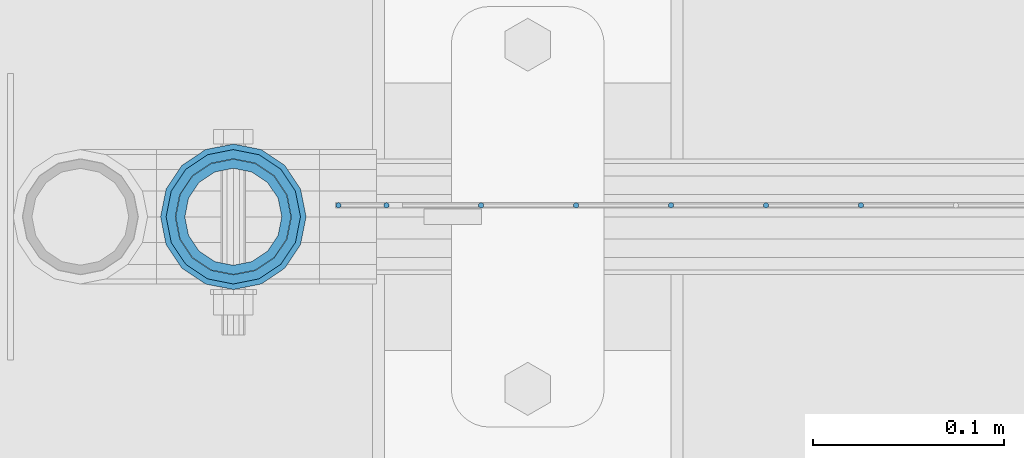
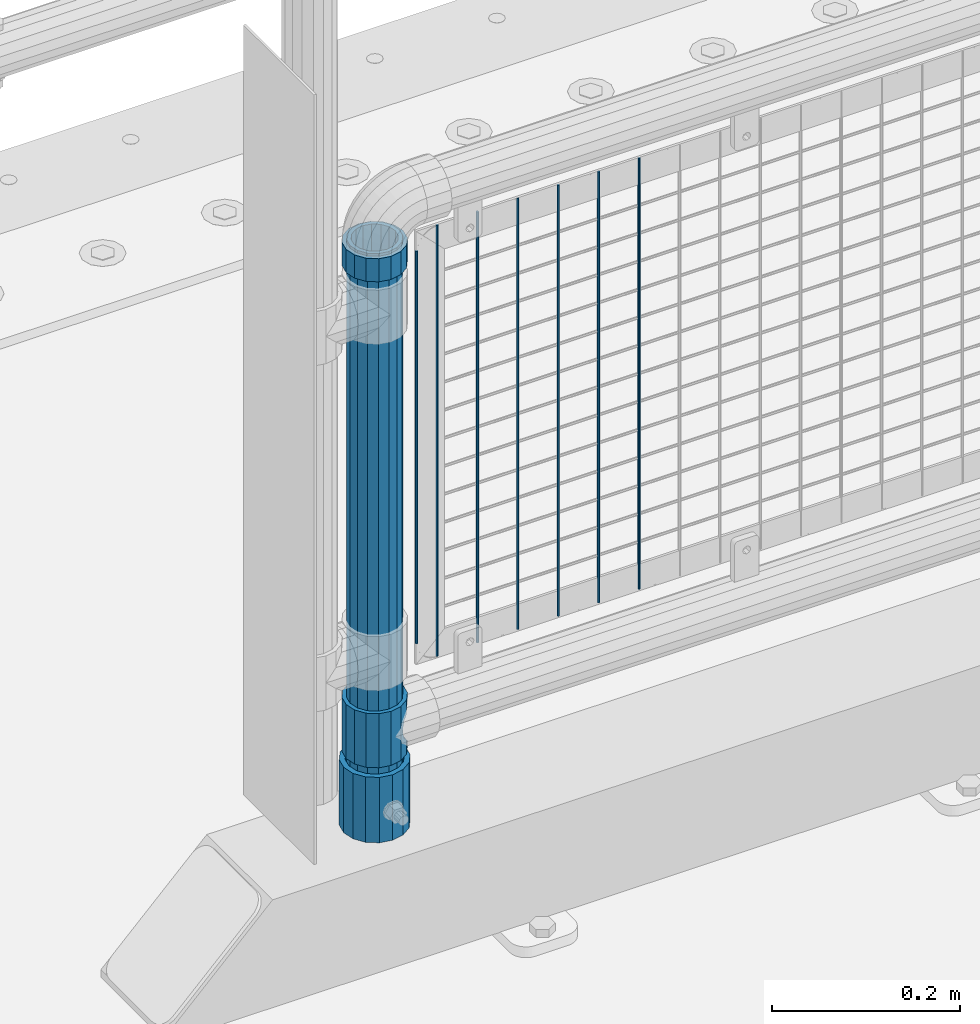
# One storey, part 54 of 208: 11 columns.
"""IFC2X3 building model written with IfcOpenShell, lengths in millimetres."""

from ifc_helpers import new_model, si_unit, frame, origin_with_axes, place, context, subcontext, project, spatial, faceted_brep, material, type_object, element, save


model = new_model("IFC2X3")

# Units and contexts
model_context = context("Model", 3, precision=1e-05, world=origin_with_axes())
body_context = subcontext(model_context, "Body", "Model", "MODEL_VIEW")
ifc_project = project(units=[si_unit("LENGTHUNIT", "METRE", prefix="MILLI"), si_unit("AREAUNIT", "SQUARE_METRE"), si_unit("VOLUMEUNIT", "CUBIC_METRE"), si_unit("MASSUNIT", "GRAM", prefix="KILO"), si_unit("TIMEUNIT", "SECOND"), si_unit("PLANEANGLEUNIT", "RADIAN"), si_unit("SOLIDANGLEUNIT", "STERADIAN"), si_unit("THERMODYNAMICTEMPERATUREUNIT", "DEGREE_CELSIUS"), si_unit("LUMINOUSINTENSITYUNIT", "LUMEN")], contexts=[model_context])

# Site, building, storey
site_placement = place(None, origin_with_axes())
site = spatial("IfcSite", under=ifc_project, at=site_placement, CompositionType="ELEMENT")
building_placement = place(site_placement, origin_with_axes())
building = spatial("IfcBuilding", under=site, at=building_placement, Name="Standard", CompositionType="ELEMENT")
storey_placement = place(building_placement, origin_with_axes())
storey = spatial("IfcBuildingStorey", under=building, at=storey_placement, Name="Undefined", CompositionType="ELEMENT", Elevation=0.0)

# Columns
ifc_material_1 = material()
column_type_1 = type_object("IfcColumnType", PredefinedType="NOTDEFINED")
column_1_placement = place(storey_placement, frame((-41829.0000001958, 4664.5, 168.019999999998), z_axis=(0.0, 1.0, 0.0), x_axis=(0.0, 0.0, 1.0)))
element("IfcColumn", 1, at=column_1_placement, inside=storey, type_object=column_type_1, material=ifc_material_1, context=body_context, shape_type="Brep", body=[
    faceted_brep([(0.0, -31.75, 0.0), (0.0, -29.3331751572332, 12.1501989775916), (85.0, -29.3331751572332, 12.1501989775916), (85.0, -31.75, 0.0), (0.0, -22.4506403026717, 22.4506403026726), (85.0, -22.4506403026717, 22.4506403026726), (0.0, -12.1501989775934, 29.3331751572332), (85.0, -12.1501989775934, 29.3331751572332), (0.0, 0.0, 31.75), (85.0, 0.0, 31.75), (0.0, 12.1501989775934, 29.3331751572332), (85.0, 12.1501989775934, 29.3331751572332), (0.0, 22.4506403026717, 22.4506403026726), (85.0, 22.4506403026717, 22.4506403026726), (0.0, 29.3331751572332, 12.1501989775916), (85.0, 29.3331751572332, 12.1501989775916), (0.0, 31.75, 0.0), (85.0, 31.75, 0.0), (0.0, 29.3331751572332, -12.1501989775916), (85.0, 29.3331751572332, -12.1501989775916), (0.0, 22.4506403026717, -22.4506403026726), (85.0, 22.4506403026717, -22.4506403026726), (0.0, 12.1501989775934, -29.3331751572332), (85.0, 12.1501989775934, -29.3331751572332), (0.0, 0.0, -31.75), (85.0, 0.0, -31.75), (0.0, -12.1501989775934, -29.3331751572332), (85.0, -12.1501989775934, -29.3331751572332), (0.0, -22.4506403026717, -22.4506403026726), (85.0, -22.4506403026717, -22.4506403026726), (0.0, -29.3331751572332, -12.1501989775916), (85.0, -29.3331751572332, -12.1501989775916), (0.0, -38.0499999999993, 0.0), (0.0, -35.1536162120537, -14.5611046014919), (85.0, -35.1536162120537, -14.5611046014919), (85.0, -38.0499999999993, 0.0), (0.0, -26.9054130241493, -26.9054130241484), (85.0, -26.9054130241493, -26.9054130241484), (0.0, -14.5611046014928, -35.1536162120547), (85.0, -14.5611046014928, -35.1536162120547), (0.0, 0.0, -38.0500000000002), (85.0, 0.0, -38.0500000000002), (0.0, 14.5611046014928, -35.1536162120547), (85.0, 14.5611046014928, -35.1536162120547), (0.0, 26.9054130241493, -26.9054130241484), (85.0, 26.9054130241493, -26.9054130241484), (0.0, 35.1536162120537, -14.5611046014919), (85.0, 35.1536162120537, -14.5611046014919), (0.0, 38.0499999999993, 0.0), (85.0, 38.0499999999993, 0.0), (0.0, 35.1536162120537, 14.5611046014919), (85.0, 35.1536162120537, 14.5611046014919), (0.0, 26.9054130241493, 26.9054130241484), (85.0, 26.9054130241493, 26.9054130241484), (0.0, 14.5611046014928, 35.1536162120547), (85.0, 14.5611046014928, 35.1536162120547), (0.0, 0.0, 38.0500000000002), (85.0, 0.0, 38.0500000000002), (0.0, -14.5611046014928, 35.1536162120547), (85.0, -14.5611046014928, 35.1536162120547), (0.0, -26.9054130241493, 26.9054130241484), (85.0, -26.9054130241493, 26.9054130241484), (0.0, -35.1536162120537, 14.5611046014919), (85.0, -35.1536162120537, 14.5611046014919)], [[[0, 1, 2, 3]], [[1, 4, 5, 2]], [[4, 6, 7, 5]], [[6, 8, 9, 7]], [[8, 10, 11, 9]], [[10, 12, 13, 11]], [[12, 14, 15, 13]], [[14, 16, 17, 15]], [[16, 18, 19, 17]], [[18, 20, 21, 19]], [[20, 22, 23, 21]], [[22, 24, 25, 23]], [[24, 26, 27, 25]], [[26, 28, 29, 27]], [[28, 30, 31, 29]], [[30, 0, 3, 31]], [[32, 33, 34, 35]], [[33, 36, 37, 34]], [[36, 38, 39, 37]], [[38, 40, 41, 39]], [[40, 42, 43, 41]], [[42, 44, 45, 43]], [[44, 46, 47, 45]], [[46, 48, 49, 47]], [[48, 50, 51, 49]], [[50, 52, 53, 51]], [[52, 54, 55, 53]], [[54, 56, 57, 55]], [[56, 58, 59, 57]], [[58, 60, 61, 59]], [[60, 62, 63, 61]], [[62, 32, 35, 63]], [[37, 39, 41, 43, 45, 47, 49, 51, 53, 55, 57, 59, 61, 63, 35, 34], [5, 7, 9, 11, 13, 15, 17, 19, 21, 23, 25, 27, 29, 31, 3, 2]], [[62, 60, 58, 56, 54, 52, 50, 48, 46, 44, 42, 40, 38, 36, 33, 32], [30, 28, 26, 24, 22, 20, 18, 16, 14, 12, 10, 8, 6, 4, 1, 0]]]),
])
ifc_material_2 = material(Name="Misc_Undefined")
column_type_2 = type_object("IfcColumnType", PredefinedType="NOTDEFINED")
column_2_placement = place(storey_placement, frame((-41829.0, 4664.5, 263.52), z_axis=(-1.0, 0.0, 0.0), x_axis=(0.0, 0.0, 1.0)))
element("IfcColumn", 2, at=column_2_placement, inside=storey, type_object=column_type_2, material=ifc_material_2, context=body_context, shape_type="Brep", body=[
    faceted_brep([(63.1897438117172, 11.6144421722802, -32.8397438117245), (63.1897438117172, 11.6144421722802, -28.0397438117143), (56.6106908090114, 21.4606908090118, -21.4606908090136), (56.6106908090114, 21.4606908090118, -27.1226768591077), (61.962379517676, 13.4513226476329, -32.4743655677739), (46.7644421722801, 28.0397438117179, -11.6144421722784), (46.7644421722801, 28.0397438117179, -20.0882031229921), (51.531042408003, 24.8548033587067, -24.8548033587067), (35.1500000000015, 30.35, 0.0), (35.1499999999996, 30.3500000000004, -16.6306603983685), (23.5355578277192, 28.0397438117179, -11.6144421722784), (23.5355578277192, 28.0397438117179, -20.0882031229921), (18.7689575919962, 24.8548033587067, -24.8548033587067), (13.6893091909879, 21.4606908090118, -21.4606908090136), (13.6893091909879, 21.4606908090118, -27.1226768591077), (8.33762048232325, 13.4513226476329, -32.4743655677739), (7.11025618828211, 11.6144421722802, -28.0397438117143), (7.11025618828211, 11.6144421722802, -32.8397438117245), (4.79999999999961, 0.0, -30.3499999999985), (4.79999999999961, 0.0, -35.1500000000015), (7.11025618828205, -11.6144421722802, -28.0397438117143), (7.11025618828205, -11.6144421722802, -32.8397438117245), (13.6893091909879, -21.4606908090118, -21.4606908090136), (13.6893091909879, -21.4606908090118, -27.1226768591005), (8.33762048232325, -13.4513226476329, -32.4743655677739), (23.5355578277191, -28.0397438117179, -11.6144421722784), (23.5355578277191, -28.0397438117179, -20.0882031229921), (18.7689575919962, -24.8548033587067, -24.8548033587067), (35.1500000000015, -30.35, 0.0), (35.1499999999996, -30.3500000000004, -16.6306603983685), (46.7644421722801, -28.0397438117179, -11.6144421722784), (46.7644421722801, -28.0397438117179, -20.0882031229921), (51.531042408003, -24.8548033587067, -24.8548033587067), (56.6106908090114, -21.4606908090118, -21.4606908090136), (56.6106908090114, -21.4606908090118, -27.1226768591005), (61.962379517675, -13.4513226476329, -32.4743655677739), (63.1897438117172, -11.6144421722802, -28.0397438117143), (63.1897438117172, -11.6144421722802, -32.8397438117245), (65.4999999999997, 0.0, -30.3499999999985), (65.4999999999997, 0.0, -35.1500000000015), (70.2999999999993, -11.6144421722802, -28.0397438117143), (70.2999999999993, 0.0, -30.3499999999985), (70.2999999999993, -21.4606908090118, -21.4606908090136), (70.2999999999993, -28.0397438117179, -11.6144421722784), (70.2999999999993, -30.3500000000004, 0.0), (0.0, -28.0397438117179, -11.6144421722784), (0.0, -30.3500000000004, 0.0), (0.0, -21.4606908090118, -21.4606908090136), (0.0, -11.6144421722802, -28.0397438117143), (0.0, 0.0, -30.3499999999985), (0.0, 11.6144421722802, -28.0397438117143), (0.0, 21.4606908090118, -21.4606908090136), (0.0, 28.0397438117179, -11.6144421722784), (0.0, 30.3500000000004, 0.0), (0.0, -24.8548033587067, -24.8548033587067), (0.0, -13.4513226476329, -32.4743655677739), (0.0, 0.0, -35.1499999999996), (0.0, 13.4513226476329, -32.4743655677739), (0.0, 24.8548033587067, -24.8548033587067), (0.0, -32.4743655677721, 13.4513226476338), (0.0, -35.1499999999996, 0.0), (70.2999999999993, -35.1499999999996, 0.0), (70.2999999999993, -32.4743655677721, 13.4513226476338), (0.0, -24.8548033587067, 24.8548033587067), (70.2999999999993, -24.8548033587067, 24.8548033587067), (0.0, -13.4513226476329, 32.4743655677739), (70.2999999999993, -13.4513226476329, 32.4743655677739), (0.0, 0.0, 35.1499999999996), (70.2999999999993, 0.0, 35.1500000000015), (0.0, 13.4513226476329, 32.4743655677739), (70.2999999999993, 13.4513226476329, 32.4743655677739), (0.0, 24.8548033587067, 24.8548033587067), (70.2999999999993, 24.8548033587067, 24.8548033587067), (0.0, 32.4743655677721, 13.4513226476338), (70.2999999999993, 32.4743655677721, 13.4513226476338), (0.0, 35.1499999999996, 0.0), (70.2999999999993, 35.1499999999996, 0.0), (0.0, 32.4743655677721, -13.4513226476338), (70.2999999999993, 32.4743655677721, -13.4513226476338), (70.2999999999993, 24.8548033587067, -24.8548033587067), (70.2999999999993, 13.4513226476329, -32.4743655677739), (70.2999999999993, 0.0, -35.1500000000015), (70.2999999999993, -13.4513226476329, -32.4743655677739), (70.2999999999993, -24.8548033587067, -24.8548033587067), (70.2999999999993, -32.4743655677721, -13.4513226476338), (0.0, -32.4743655677721, -13.4513226476338), (0.0, 28.0397438117179, 11.6144421722784), (0.0, 21.4606908090118, 21.4606908090136), (0.0, 11.6144421722802, 28.0397438117143), (0.0, 0.0, 30.3499999999985), (0.0, -11.6144421722802, 28.0397438117143), (0.0, -21.4606908090118, 21.4606908090136), (0.0, -28.0397438117179, 11.6144421722784), (70.2999999999993, 28.0397438117179, 11.6144421722784), (70.2999999999993, 21.4606908090118, 21.4606908090136), (70.2999999999993, 11.6144421722802, 28.0397438117143), (70.2999999999993, 0.0, 30.3499999999985), (70.2999999999993, -11.6144421722802, 28.0397438117143), (70.2999999999993, -21.4606908090118, 21.4606908090136), (70.2999999999993, -28.0397438117179, 11.6144421722784), (70.2999999999993, 30.3500000000004, 0.0), (70.2999999999993, 28.0397438117179, -11.6144421722784), (70.2999999999993, 21.4606908090118, -21.4606908090136), (70.2999999999993, 11.6144421722802, -28.0397438117143)], [[[0, 1, 2, 3, 4]], [[3, 2, 5, 6, 7]], [[6, 5, 8, 9]], [[9, 8, 10, 11]], [[12, 11, 10, 13, 14]], [[15, 14, 13, 16, 17]], [[17, 16, 18, 19]], [[19, 18, 20, 21]], [[21, 20, 22, 23, 24]], [[23, 22, 25, 26, 27]], [[26, 25, 28, 29]], [[29, 28, 30, 31]], [[32, 31, 30, 33, 34]], [[35, 34, 33, 36, 37]], [[37, 36, 38, 39]], [[39, 38, 1, 0]], [[40, 41, 38, 36]], [[42, 40, 36, 33]], [[43, 42, 33, 30]], [[44, 43, 30, 28]], [[45, 46, 28, 25]], [[47, 45, 25, 22]], [[48, 47, 22, 20]], [[49, 48, 20, 18]], [[50, 49, 18, 16]], [[51, 50, 16, 13]], [[52, 51, 13, 10]], [[53, 52, 10, 8]], [[27, 54, 55, 24, 23]], [[24, 55, 56, 19, 21]], [[56, 57, 15, 17, 19]], [[57, 58, 12, 14, 15]], [[59, 60, 61, 62]], [[63, 59, 62, 64]], [[65, 63, 64, 66]], [[67, 65, 66, 68]], [[69, 67, 68, 70]], [[71, 69, 70, 72]], [[73, 71, 72, 74]], [[75, 73, 74, 76]], [[77, 75, 76, 78]], [[9, 11, 12, 58, 77, 78, 79, 7, 6]], [[7, 79, 80, 4, 3]], [[4, 80, 81, 39, 0]], [[82, 83, 32, 34, 35]], [[81, 82, 35, 37, 39]], [[83, 84, 85, 54, 27, 26, 29, 31, 32]], [[60, 85, 84, 61]], [[59, 63, 65, 67, 69, 71, 73, 75, 77, 58, 57, 56, 55, 54, 85, 60], [45, 47, 48, 49, 50, 51, 52, 53, 86, 87, 88, 89, 90, 91, 92, 46]], [[87, 86, 93, 94]], [[88, 87, 94, 95]], [[89, 88, 95, 96]], [[90, 89, 96, 97]], [[91, 90, 97, 98]], [[92, 91, 98, 99]], [[28, 46, 92, 99, 44]], [[83, 82, 81, 80, 79, 78, 76, 74, 72, 70, 68, 66, 64, 62, 61, 84], [98, 97, 96, 95, 94, 93, 100, 101, 102, 103, 41, 40, 42, 43, 44, 99]], [[86, 53, 8, 100, 93]], [[101, 100, 8, 5]], [[102, 101, 5, 2]], [[103, 102, 2, 1]], [[41, 103, 1, 38]]]),
])
column_3_placement = place(storey_placement, frame((-41829.0, 4664.5, 894.849999999999), z_axis=(-1.0, 0.0, 0.0), x_axis=(0.0, 0.0, 1.0)))
element("IfcColumn", 3, at=column_3_placement, inside=storey, type_object=column_type_2, material=ifc_material_2, context=body_context, shape_type="Brep", body=[
    faceted_brep([(0.0, -30.3500000000004, 0.0), (0.0, -28.0397438117179, 11.6144421722784), (30.0, -28.0397438117179, 11.6144421722805), (30.0, -30.3500000000004, 0.0), (0.0, -21.4606908090118, 21.4606908090136), (30.0, -21.4606908090118, 21.4606908090117), (0.0, -11.6144421722802, 28.0397438117143), (30.0, -11.6144421722802, 28.0397438117175), (0.0, 0.0, 30.3499999999985), (30.0, 0.0, 30.35), (0.0, 11.6144421722802, 28.0397438117143), (30.0, 11.6144421722802, 28.0397438117175), (0.0, 21.4606908090118, 21.4606908090136), (30.0, 21.4606908090118, 21.4606908090117), (0.0, 28.0397438117179, 11.6144421722784), (30.0, 28.0397438117179, 11.6144421722805), (0.0, 30.3500000000004, 0.0), (30.0, 30.3500000000004, 0.0), (0.0, 28.0397438117179, -11.6144421722784), (30.0, 28.0397438117179, -11.6144421722805), (0.0, 21.4606908090118, -21.4606908090136), (30.0, 21.4606908090118, -21.4606908090117), (0.0, 11.6144421722802, -28.0397438117143), (30.0, 11.6144421722802, -28.0397438117175), (0.0, 0.0, -30.3499999999985), (30.0, 0.0, -30.35), (0.0, -11.6144421722802, -28.0397438117143), (30.0, -11.6144421722802, -28.0397438117175), (0.0, -21.4606908090118, -21.4606908090136), (30.0, -21.4606908090118, -21.4606908090117), (0.0, -28.0397438117179, -11.6144421722784), (30.0, -28.0397438117179, -11.6144421722805), (0.0, -35.1499999999996, 0.0), (0.0, -32.4743655677721, -13.4513226476338), (30.0, -32.4743655677721, -13.4513226476329), (30.0, -35.1499999999996, 0.0), (0.0, -24.8548033587067, -24.8548033587067), (30.0, -24.8548033587067, -24.8548033587072), (0.0, -13.4513226476329, -32.4743655677739), (30.0, -13.4513226476329, -32.4743655677717), (0.0, 0.0, -35.1499999999996), (30.0, 0.0, -35.15), (0.0, 13.4513226476329, -32.4743655677739), (30.0, 13.4513226476329, -32.4743655677717), (0.0, 24.8548033587067, -24.8548033587067), (30.0, 24.8548033587067, -24.8548033587072), (0.0, 32.4743655677721, -13.4513226476338), (30.0, 32.4743655677721, -13.4513226476329), (0.0, 35.1499999999996, 0.0), (30.0, 35.1499999999996, 0.0), (0.0, 32.4743655677721, 13.4513226476338), (30.0, 32.4743655677721, 13.4513226476329), (0.0, 24.8548033587067, 24.8548033587067), (30.0, 24.8548033587067, 24.8548033587072), (0.0, 13.4513226476329, 32.4743655677739), (30.0, 13.4513226476329, 32.4743655677717), (0.0, 0.0, 35.1499999999996), (30.0, 0.0, 35.15), (0.0, -13.4513226476329, 32.4743655677739), (30.0, -13.4513226476329, 32.4743655677717), (0.0, -24.8548033587067, 24.8548033587067), (30.0, -24.8548033587067, 24.8548033587072), (0.0, -32.4743655677721, 13.4513226476338), (30.0, -32.4743655677721, 13.4513226476329)], [[[0, 1, 2, 3]], [[1, 4, 5, 2]], [[4, 6, 7, 5]], [[6, 8, 9, 7]], [[8, 10, 11, 9]], [[10, 12, 13, 11]], [[12, 14, 15, 13]], [[14, 16, 17, 15]], [[16, 18, 19, 17]], [[18, 20, 21, 19]], [[20, 22, 23, 21]], [[22, 24, 25, 23]], [[24, 26, 27, 25]], [[26, 28, 29, 27]], [[28, 30, 31, 29]], [[30, 0, 3, 31]], [[32, 33, 34, 35]], [[33, 36, 37, 34]], [[36, 38, 39, 37]], [[38, 40, 41, 39]], [[40, 42, 43, 41]], [[42, 44, 45, 43]], [[44, 46, 47, 45]], [[46, 48, 49, 47]], [[48, 50, 51, 49]], [[50, 52, 53, 51]], [[52, 54, 55, 53]], [[54, 56, 57, 55]], [[56, 58, 59, 57]], [[58, 60, 61, 59]], [[60, 62, 63, 61]], [[62, 32, 35, 63]], [[37, 39, 41, 43, 45, 47, 49, 51, 53, 55, 57, 59, 61, 63, 35, 34], [5, 7, 9, 11, 13, 15, 17, 19, 21, 23, 25, 27, 29, 31, 3, 2]], [[62, 60, 58, 56, 54, 52, 50, 48, 46, 44, 42, 40, 38, 36, 33, 32], [30, 28, 26, 24, 22, 20, 18, 16, 14, 12, 10, 8, 6, 4, 1, 0]]]),
])
column_type_3 = type_object("IfcColumnType", PredefinedType="NOTDEFINED")
column_4_placement = place(storey_placement, frame((-41829.0000001958, 4664.5, 168.019999999998), z_axis=(-1.0, 0.0, 0.0), x_axis=(0.0, 0.0, 1.0)))
element("IfcColumn", 4, at=column_4_placement, inside=storey, type_object=column_type_3, material=ifc_material_1, context=body_context, shape_type="Brep", body=[
    faceted_brep([(0.0, -25.3500000000004, 0.0), (0.0, -23.4203461491616, 9.70102501045403), (760.0, -23.4203461491616, 9.70102501045403), (760.0, -25.3500000000004, 0.0), (0.0, -17.9251569030794, 17.9251569030785), (760.0, -17.9251569030794, 17.9251569030785), (0.0, -9.70102501045494, 23.4203461491597), (760.0, -9.70102501045494, 23.4203461491597), (0.0, 0.0, 25.3499999999985), (760.0, 0.0, 25.3499999999985), (0.0, 9.70102501045494, 23.4203461491597), (760.0, 9.70102501045494, 23.4203461491597), (0.0, 17.9251569030794, 17.9251569030785), (760.0, 17.9251569030794, 17.9251569030785), (0.0, 23.4203461491616, 9.70102501045403), (760.0, 23.4203461491616, 9.70102501045403), (0.0, 25.3500000000004, 0.0), (760.0, 25.3500000000004, 0.0), (0.0, 23.4203461491616, -9.70102501045403), (760.0, 23.4203461491616, -9.70102501045403), (0.0, 17.9251569030794, -17.9251569030785), (760.0, 17.9251569030794, -17.9251569030785), (0.0, 9.70102501045494, -23.4203461491597), (760.0, 9.70102501045494, -23.4203461491597), (0.0, 0.0, -25.3499999999985), (760.0, 0.0, -25.3499999999985), (0.0, -9.70102501045494, -23.4203461491597), (760.0, -9.70102501045494, -23.4203461491597), (0.0, -17.9251569030794, -17.9251569030785), (760.0, -17.9251569030794, -17.9251569030785), (0.0, -23.4203461491616, -9.70102501045403), (760.0, -23.4203461491616, -9.70102501045403), (0.0, -30.1499999999996, 0.0), (0.0, -27.8549679052148, -11.5379054858058), (760.0, -27.8549679052148, -11.5379054858058), (760.0, -30.1499999999996, 0.0), (0.0, -21.3192694527743, -21.3192694527752), (760.0, -21.3192694527743, -21.3192694527752), (0.0, -11.5379054858076, -27.8549679052157), (760.0, -11.5379054858076, -27.8549679052157), (0.0, 0.0, -30.1500000000015), (760.0, 0.0, -30.1500000000015), (0.0, 11.5379054858076, -27.8549679052157), (760.0, 11.5379054858076, -27.8549679052157), (0.0, 21.3192694527743, -21.3192694527752), (760.0, 21.3192694527743, -21.3192694527752), (0.0, 27.8549679052157, -11.5379054858058), (760.0, 27.8549679052157, -11.5379054858058), (0.0, 30.1499999999996, 0.0), (760.0, 30.1499999999996, 0.0), (0.0, 27.8549679052157, 11.5379054858058), (760.0, 27.8549679052157, 11.5379054858058), (0.0, 21.3192694527743, 21.3192694527752), (760.0, 21.3192694527743, 21.3192694527752), (0.0, 11.5379054858076, 27.8549679052157), (760.0, 11.5379054858076, 27.8549679052157), (0.0, 0.0, 30.1500000000015), (760.0, 0.0, 30.1500000000015), (0.0, -11.5379054858076, 27.8549679052157), (760.0, -11.5379054858076, 27.8549679052157), (0.0, -21.3192694527743, 21.3192694527752), (760.0, -21.3192694527743, 21.3192694527752), (0.0, -27.8549679052157, 11.5379054858058), (760.0, -27.8549679052157, 11.5379054858058)], [[[0, 1, 2, 3]], [[1, 4, 5, 2]], [[4, 6, 7, 5]], [[6, 8, 9, 7]], [[8, 10, 11, 9]], [[10, 12, 13, 11]], [[12, 14, 15, 13]], [[14, 16, 17, 15]], [[16, 18, 19, 17]], [[18, 20, 21, 19]], [[20, 22, 23, 21]], [[22, 24, 25, 23]], [[24, 26, 27, 25]], [[26, 28, 29, 27]], [[28, 30, 31, 29]], [[30, 0, 3, 31]], [[32, 33, 34, 35]], [[33, 36, 37, 34]], [[36, 38, 39, 37]], [[38, 40, 41, 39]], [[40, 42, 43, 41]], [[42, 44, 45, 43]], [[44, 46, 47, 45]], [[46, 48, 49, 47]], [[48, 50, 51, 49]], [[50, 52, 53, 51]], [[52, 54, 55, 53]], [[54, 56, 57, 55]], [[56, 58, 59, 57]], [[58, 60, 61, 59]], [[60, 62, 63, 61]], [[62, 32, 35, 63]], [[37, 39, 41, 43, 45, 47, 49, 51, 53, 55, 57, 59, 61, 63, 35, 34], [5, 7, 9, 11, 13, 15, 17, 19, 21, 23, 25, 27, 29, 31, 3, 2]], [[62, 60, 58, 56, 54, 52, 50, 48, 46, 44, 42, 40, 38, 36, 33, 32], [30, 28, 26, 24, 22, 20, 18, 16, 14, 12, 10, 8, 6, 4, 1, 0]]]),
])
column_type_4 = type_object("IfcColumnType", Name="D3", PredefinedType="NOTDEFINED")
for number, where, z_axis, x_axis in (
    (5, (-41500.725, 4670.5, 353.02), (-1.0, 0.0, 0.0), (0.0, 0.0, 1.0)),
    (6, (-41550.38, 4670.5, 353.02), (-1.0, 0.0, 0.0), (0.0, 0.0, 1.0)),
    (7, (-41600.035, 4670.5, 353.02), (-1.0, 0.0, 0.0), (0.0, 0.0, 1.0)),
    (8, (-41649.6896551724, 4670.5, 353.02), (-0.999999999851374, 0.0, 1.72409999974503e-05), (1.72409999946567e-05, 0.0, 0.999999999851374)),
    (9, (-41699.3448275862, 4670.5, 353.02), (-0.999999999962839, 0.0, 8.62099999968473e-06), (8.62099999949798e-06, 0.0, 0.999999999962839)),
):
    element("IfcColumn", number, at=place(storey_placement, frame(where, z_axis=z_axis, x_axis=x_axis)), inside=storey, type_object=column_type_4, material=ifc_material_2, ObjectType="D3", context=body_context, shape_type="Brep", body=[
        faceted_brep([(0.0, -1.49999999999909, 3.63797880709171e-12), (-7.27595761418343e-12, -0.749999999999091, -1.29903810567669), (560.0, -0.75, -1.29903810567703), (560.0, -1.5, 0.0), (-3.63797880709171e-12, 0.750000000000909, -1.29903810567669), (560.0, 0.75, -1.29903810567703), (0.0, 1.50000000000182, 3.63797880709171e-12), (560.0, 1.5, 0.0), (-3.63797880709171e-12, 0.750000000000909, 1.29903810567669), (560.0, 0.75, 1.29903810567703), (-7.27595761418343e-12, -0.749999999999091, 1.29903810567669), (560.0, -0.75, 1.29903810567703)], [[[0, 1, 2, 3]], [[1, 4, 5, 2]], [[4, 6, 7, 5]], [[6, 8, 9, 7]], [[8, 10, 11, 9]], [[10, 0, 3, 11]], [[5, 7, 9, 11, 3, 2]], [[10, 8, 6, 4, 1, 0]]]),
    ])
column_5_placement = place(storey_placement, frame((-41774.0, 4670.5, 378.02), z_axis=(-1.0, 0.0, 0.0), x_axis=(0.0, 0.0, 1.0)))
element("IfcColumn", 10, at=column_5_placement, inside=storey, type_object=column_type_4, material=ifc_material_2, ObjectType="D3", context=body_context, shape_type="Brep", body=[
    faceted_brep([(0.0, -1.49999999999909, 3.63797880709171e-12), (-7.27595761418343e-12, -0.749999999999091, -1.29903810567669), (510.0, -0.75, -1.29903810567703), (510.0, -1.5, 0.0), (-3.63797880709171e-12, 0.750000000000909, -1.29903810567669), (510.0, 0.75, -1.29903810567703), (0.0, 1.50000000000182, 3.63797880709171e-12), (510.0, 1.5, 0.0), (-3.63797880709171e-12, 0.750000000000909, 1.29903810567669), (510.0, 0.75, 1.29903810567703), (-7.27595761418343e-12, -0.749999999999091, 1.29903810567669), (510.0, -0.75, 1.29903810567703)], [[[0, 1, 2, 3]], [[1, 4, 5, 2]], [[4, 6, 7, 5]], [[6, 8, 9, 7]], [[8, 10, 11, 9]], [[10, 0, 3, 11]], [[5, 7, 9, 11, 3, 2]], [[10, 8, 6, 4, 1, 0]]]),
])
column_6_placement = place(storey_placement, frame((-41749.0, 4670.5, 353.02), z_axis=(-1.0, 0.0, 0.0), x_axis=(0.0, 0.0, 1.0)))
element("IfcColumn", 11, at=column_6_placement, inside=storey, type_object=column_type_4, material=ifc_material_2, ObjectType="D3", context=body_context, shape_type="Brep", body=[
    faceted_brep([(0.0, -1.49999999999909, 3.63797880709171e-12), (-7.27595761418343e-12, -0.749999999999091, -1.29903810567669), (560.0, -0.75, -1.29903810567703), (560.0, -1.5, 0.0), (-3.63797880709171e-12, 0.750000000000909, -1.29903810567669), (560.0, 0.75, -1.29903810567703), (0.0, 1.50000000000182, 3.63797880709171e-12), (560.0, 1.5, 0.0), (-3.63797880709171e-12, 0.750000000000909, 1.29903810567669), (560.0, 0.75, 1.29903810567703), (-7.27595761418343e-12, -0.749999999999091, 1.29903810567669), (560.0, -0.75, 1.29903810567703)], [[[0, 1, 2, 3]], [[1, 4, 5, 2]], [[4, 6, 7, 5]], [[6, 8, 9, 7]], [[8, 10, 11, 9]], [[10, 0, 3, 11]], [[5, 7, 9, 11, 3, 2]], [[10, 8, 6, 4, 1, 0]]]),
])

save(model, "model.ifc")
